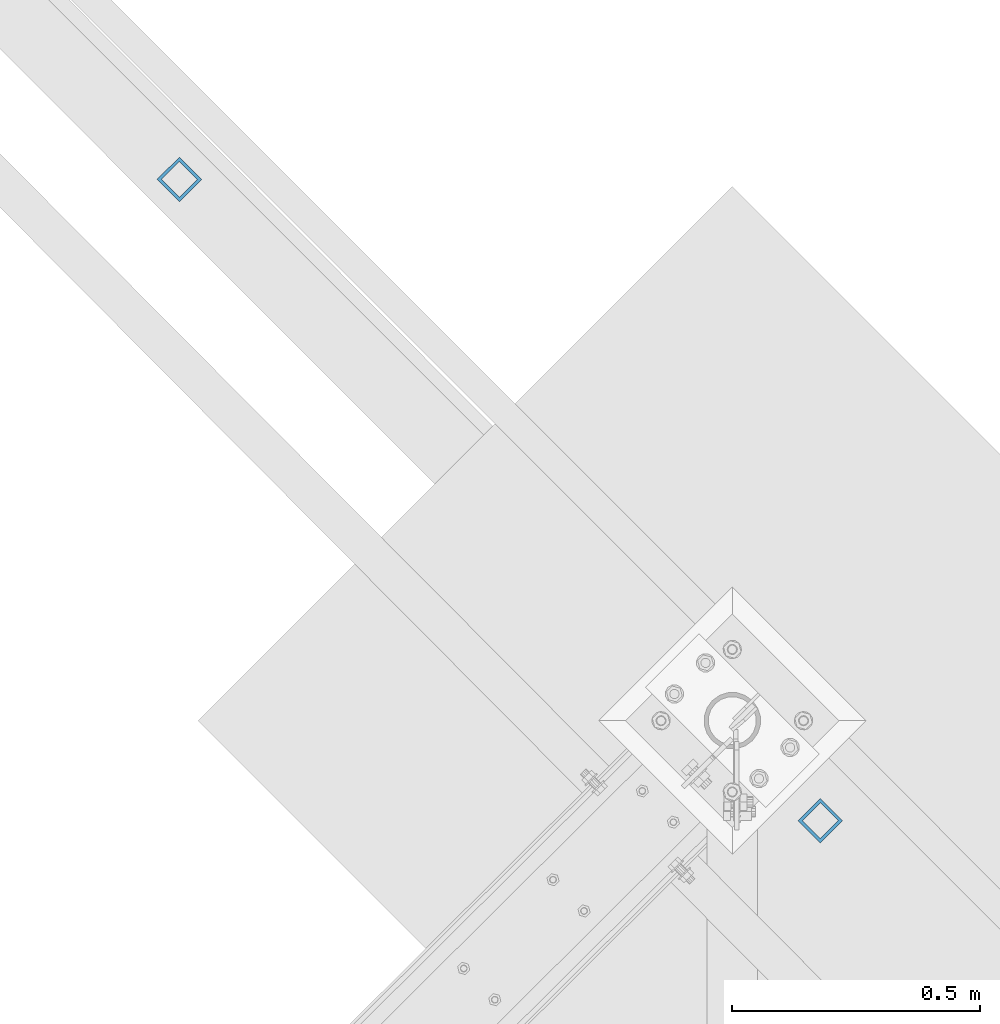
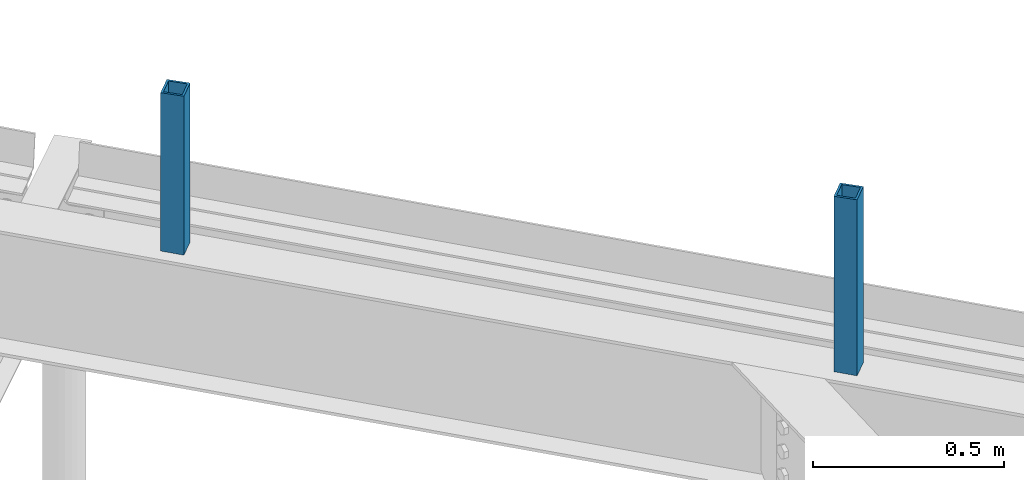
# One storey, part 281 of 975: 2 columns.
"""IFC2X3 building model written with IfcOpenShell, lengths in millimetres."""

from ifc_helpers import new_model, si_unit, frame, origin_with_axes, place, context, subcontext, project, spatial, faceted_brep, material, type_object, element, save


model = new_model("IFC2X3")

# Units and contexts
model_context = context("Model", 3, precision=1e-05, world=origin_with_axes())
body_context = subcontext(model_context, "Body", "Model", "MODEL_VIEW")
ifc_project = project(units=[si_unit("LENGTHUNIT", "METRE", prefix="MILLI"), si_unit("AREAUNIT", "SQUARE_METRE"), si_unit("VOLUMEUNIT", "CUBIC_METRE"), si_unit("MASSUNIT", "GRAM", prefix="KILO"), si_unit("TIMEUNIT", "SECOND"), si_unit("PLANEANGLEUNIT", "RADIAN"), si_unit("SOLIDANGLEUNIT", "STERADIAN"), si_unit("THERMODYNAMICTEMPERATUREUNIT", "DEGREE_CELSIUS"), si_unit("LUMINOUSINTENSITYUNIT", "LUMEN")], contexts=[model_context])

# Site, building, storey
site_placement = place(None, origin_with_axes())
site = spatial("IfcSite", under=ifc_project, at=site_placement, CompositionType="ELEMENT")
building_placement = place(site_placement, origin_with_axes())
building = spatial("IfcBuilding", under=site, at=building_placement, Name="Undefined", CompositionType="ELEMENT")
storey_placement = place(building_placement, origin_with_axes())
storey = spatial("IfcBuildingStorey", under=building, at=storey_placement, Name="Undefined", CompositionType="ELEMENT", Elevation=0.0)

# Columns
ifc_material = material()
column_type = type_object("IfcColumnType", Name="HSS2-1/2X2-1/2X1/4", PredefinedType="NOTDEFINED")
column_1_placement = place(storey_placement, frame((28716.9410567012, 17055.7898207455, 8661.43845535944), z_axis=(0.707233416345083, 0.706980123344965, 0.0), x_axis=(0.0, 0.0, 1.0)))
element("IfcColumn", 1, at=column_1_placement, inside=storey, type_object=column_type, material=ifc_material, ObjectType="HSS2-1/2X2-1/2X1/4", context=body_context, shape_type="Brep", body=[
    faceted_brep([(533.361544640564, -31.7499999999854, 31.7500000000327), (533.361544640564, 31.7500000000364, 31.7499999999818), (24.447339799548, 31.7500000000373, 31.7499999999891), (26.3526602015227, -31.7499999999882, 31.7500000000364), (533.361544640564, -31.7500000000346, -31.7499999999891), (26.3526602015245, -31.75000000003, -31.7499999999818), (533.361544640564, 31.7499999999873, -31.75000000004), (24.4473397995498, 31.7499999999955, -31.7500000000327), (533.361544640564, -25.3999999999905, 25.4000000000233), (533.361544640564, 25.4000000000287, 25.3999999999869), (533.361544640564, 25.3999999999924, -25.4000000000306), (533.361544640564, -25.4000000000269, -25.3999999999942), (26.1621281613261, -25.399999999986, 25.4000000000306), (24.6378718397464, 25.4000000000333, 25.3999999999942), (24.6378718397464, 25.3999999999915, -25.4000000000233), (26.1621281613261, -25.400000000026, -25.3999999999869)], [[[0, 1, 2, 3]], [[4, 0, 3, 5]], [[6, 4, 5, 7]], [[1, 6, 7, 2]], [[0, 4, 6, 1], [8, 9, 10, 11]], [[9, 8, 12, 13]], [[10, 9, 13, 14]], [[11, 10, 14, 15]], [[8, 11, 15, 12]], [[7, 5, 3, 2], [14, 13, 12, 15]]]),
])
column_2_placement = place(storey_placement, frame((30009.8663063341, 15762.4013489786, 8606.56522778184), z_axis=(0.707233416345083, 0.706980123344965, 0.0), x_axis=(0.0, 0.0, 1.0)))
element("IfcColumn", 2, at=column_2_placement, inside=storey, type_object=column_type, material=ifc_material, ObjectType="HSS2-1/2X2-1/2X1/4", context=body_context, shape_type="Brep", body=[
    faceted_brep([(588.234772218164, -31.7499999999891, 31.7500000000291), (588.234772218164, 31.7500000000291, 31.7499999999854), (24.447339799548, 31.7500000000373, 31.7499999999891), (26.3526602015227, -31.7499999999882, 31.7500000000364), (588.234772218164, -31.7500000000346, -31.7499999999854), (26.3526602015245, -31.75000000003, -31.7499999999818), (588.234772218164, 31.7499999999873, -31.7500000000364), (24.4473397995498, 31.7499999999955, -31.7500000000327), (588.234772218164, -25.3999999999924, 25.4000000000233), (588.234772218164, 25.4000000000269, 25.3999999999869), (588.234772218164, 25.3999999999905, -25.4000000000306), (588.234772218164, -25.4000000000287, -25.3999999999942), (26.1621281613261, -25.399999999986, 25.4000000000306), (24.6378718397464, 25.4000000000333, 25.3999999999942), (24.6378718397464, 25.3999999999915, -25.4000000000233), (26.1621281613261, -25.400000000026, -25.3999999999869)], [[[0, 1, 2, 3]], [[4, 0, 3, 5]], [[6, 4, 5, 7]], [[1, 6, 7, 2]], [[0, 4, 6, 1], [8, 9, 10, 11]], [[9, 8, 12, 13]], [[10, 9, 13, 14]], [[11, 10, 14, 15]], [[8, 11, 15, 12]], [[7, 5, 3, 2], [14, 13, 12, 15]]]),
])

save(model, "model.ifc")
